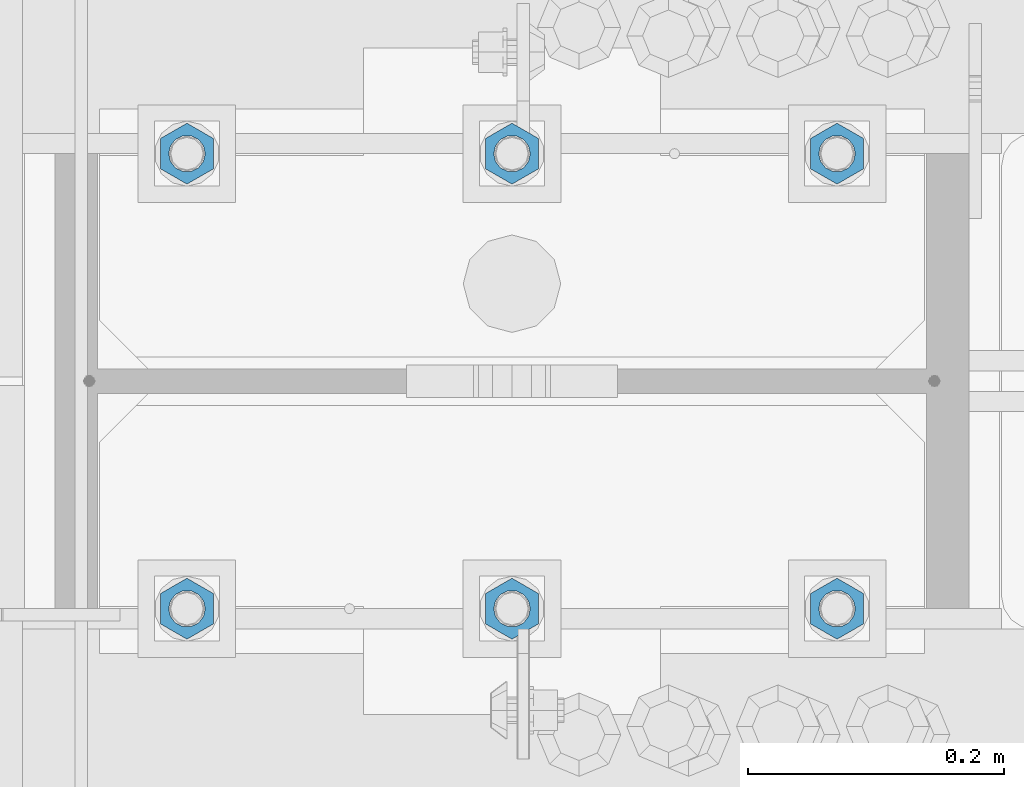
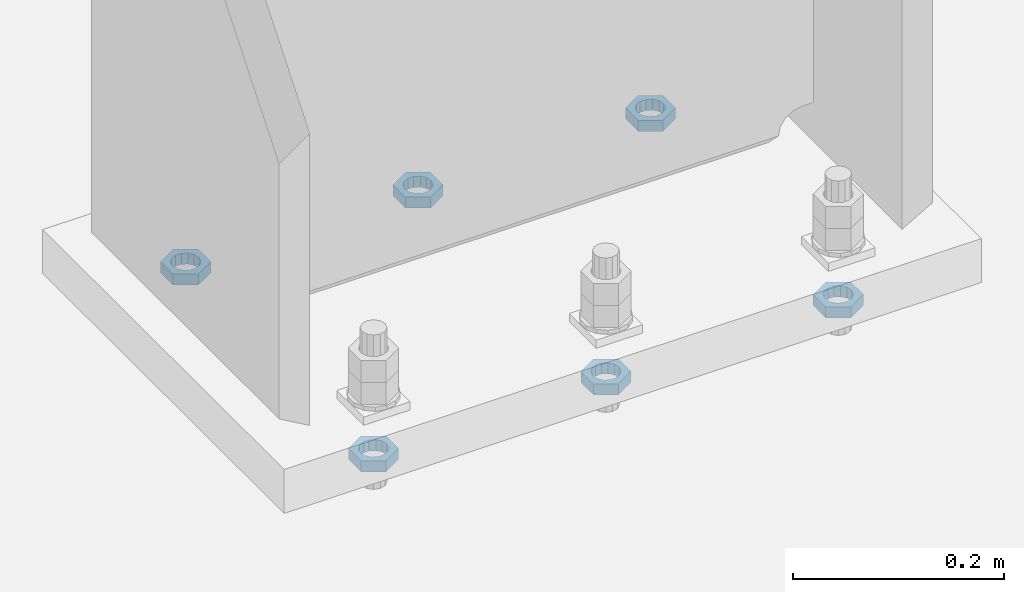
# One storey, part 1403 of 1763: 6 beams, 1 element without a shape of its own.
"""IFC2X3 building model written with IfcOpenShell, lengths in millimetres."""

from ifc_helpers import new_model, si_unit, frame, origin_with_axes, place, context, subcontext, project, spatial, faceted_brep, material, type_object, element, aggregate, save


model = new_model("IFC2X3")

# Units and contexts
model_context = context("Model", 3, precision=1e-05, world=origin_with_axes())
body_context = subcontext(model_context, "Body", "Model", "MODEL_VIEW")
ifc_project = project(units=[si_unit("LENGTHUNIT", "METRE", prefix="MILLI"), si_unit("AREAUNIT", "SQUARE_METRE"), si_unit("VOLUMEUNIT", "CUBIC_METRE"), si_unit("MASSUNIT", "GRAM", prefix="KILO"), si_unit("TIMEUNIT", "SECOND"), si_unit("PLANEANGLEUNIT", "RADIAN"), si_unit("SOLIDANGLEUNIT", "STERADIAN"), si_unit("THERMODYNAMICTEMPERATUREUNIT", "DEGREE_CELSIUS"), si_unit("LUMINOUSINTENSITYUNIT", "LUMEN")], contexts=[model_context])

# Site, building, storey
site_placement = place(None, origin_with_axes())
site = spatial("IfcSite", under=ifc_project, at=site_placement, CompositionType="ELEMENT")
building_placement = place(site_placement, origin_with_axes())
building = spatial("IfcBuilding", under=site, at=building_placement, Name="Undefined", CompositionType="ELEMENT")
storey_placement = place(building_placement, origin_with_axes())
storey = spatial("IfcBuildingStorey", under=building, at=storey_placement, Name="Undefined", CompositionType="ELEMENT", Elevation=0.0)

# Assembly, beams
assembly_placement = place(storey_placement, origin_with_axes())
assembly = element("IfcElementAssembly", 1, at=assembly_placement, inside=storey, Name="TEMPLATE", AssemblyPlace="NOTDEFINED", PredefinedType="RIGID_FRAME")
ifc_material = material(Name="STEEL/A563")
beam_type = type_object("IfcBeamType", Name="1_DIA. HALF_NUT", PredefinedType="NOTDEFINED")
beam_1_placement = place(assembly_placement, frame((-87121.4372736983, 52298.6, -266.700000000016), z_axis=(-1.0, 0.0, 0.0), x_axis=(0.0, 0.0, -1.0)))
beam_1 = element("IfcBeam", 2, at=beam_1_placement, type_object=beam_type, material=ifc_material, Name="NUT", ObjectType="1_DIA. HALF_NUT", context=body_context, shape_type="Brep", body=[
    faceted_brep([(0.0, -23.8099994659424, 0.0), (0.0, -11.9099998474121, -20.6200008392334), (12.7000000000001, -11.9099998474121, -20.6200008392334), (12.7000000000001, -23.8099994659424, 0.0), (0.0, 11.9099998474121, -20.6200008392334), (12.7000000000001, 11.9099998474121, -20.6200008392334), (0.0, 23.8099994659424, 0.0), (12.7000000000001, 23.8099994659424, 0.0), (0.0, 11.9099998474121, 20.6200008392334), (12.7000000000001, 11.9099998474121, 20.6200008392334), (0.0, -11.9099998474121, 20.6200008392334), (12.7000000000001, -11.9099998474121, 20.6200008392334), (0.0, 0.0, 14.289999961853), (0.0, 6.20019861543551, 12.8748450879575), (12.7000000000001, 6.20019861543551, 12.8748450879575), (12.7000000000001, 0.0, 14.289999961853), (0.0, 11.1723718546418, 8.90966924477834), (12.7000000000001, 11.1723718546418, 8.90966924477834), (0.0, 13.9317198278877, 3.17982413774735), (12.7000000000001, 13.9317198278877, 3.17982413774735), (0.0, 13.9317198278877, -3.17982413774735), (12.7000000000001, 13.9317198278877, -3.17982413774735), (0.0, 11.1723718546418, -8.90966924477834), (12.7000000000001, 11.1723718546418, -8.90966924477834), (0.0, 6.20019861543551, -12.8748450879575), (12.7000000000001, 6.20019861543551, -12.8748450879575), (0.0, 0.0, -14.289999961853), (12.7000000000001, 0.0, -14.289999961853), (0.0, -6.20019861543551, -12.8748450879575), (12.7000000000001, -6.20019861543551, -12.8748450879575), (0.0, -11.1723718546418, -8.90966924477834), (12.7000000000001, -11.1723718546418, -8.90966924477834), (0.0, -13.9317198278877, -3.17982413774735), (12.7000000000001, -13.9317198278877, -3.17982413774735), (0.0, -13.9317198278877, 3.17982413774735), (12.7000000000001, -13.9317198278877, 3.17982413774735), (0.0, -11.1723718546418, 8.90966924477834), (12.7000000000001, -11.1723718546418, 8.90966924477834), (0.0, -6.20019861543551, 12.8748450879575), (12.7000000000001, -6.20019861543551, 12.8748450879575)], [[[0, 1, 2, 3]], [[1, 4, 5, 2]], [[4, 6, 7, 5]], [[6, 8, 9, 7]], [[8, 10, 11, 9]], [[10, 0, 3, 11]], [[12, 13, 14, 15]], [[13, 16, 17, 14]], [[16, 18, 19, 17]], [[18, 20, 21, 19]], [[20, 22, 23, 21]], [[22, 24, 25, 23]], [[24, 26, 27, 25]], [[26, 28, 29, 27]], [[28, 30, 31, 29]], [[30, 32, 33, 31]], [[32, 34, 35, 33]], [[34, 36, 37, 35]], [[36, 38, 39, 37]], [[38, 12, 15, 39]], [[5, 7, 9, 11, 3, 2], [17, 19, 21, 23, 25, 27, 29, 31, 33, 35, 37, 39, 15, 14]], [[10, 8, 6, 4, 1, 0], [38, 36, 34, 32, 30, 28, 26, 24, 22, 20, 18, 16, 13, 12]]]),
])
beam_2_placement = place(assembly_placement, frame((-87375.4372736983, 52298.6, -266.700000000016), z_axis=(-1.0, 0.0, 0.0), x_axis=(0.0, 0.0, -1.0)))
beam_2 = element("IfcBeam", 3, at=beam_2_placement, type_object=beam_type, material=ifc_material, Name="NUT", ObjectType="1_DIA. HALF_NUT", context=body_context, shape_type="Brep", body=[
    faceted_brep([(0.0, -23.8099994659424, 0.0), (0.0, -11.9099998474121, -20.6200008392334), (12.7000000000001, -11.9099998474121, -20.6200008392334), (12.7000000000001, -23.8099994659424, 0.0), (0.0, 11.9099998474121, -20.6200008392334), (12.7000000000001, 11.9099998474121, -20.6200008392334), (0.0, 23.8099994659424, 0.0), (12.7000000000001, 23.8099994659424, 0.0), (0.0, 11.9099998474121, 20.6200008392334), (12.7000000000001, 11.9099998474121, 20.6200008392334), (0.0, -11.9099998474121, 20.6200008392334), (12.7000000000001, -11.9099998474121, 20.6200008392334), (0.0, 0.0, 14.289999961853), (0.0, 6.20019861543551, 12.8748450879575), (12.7000000000001, 6.20019861543551, 12.8748450879575), (12.7000000000001, 0.0, 14.289999961853), (0.0, 11.1723718546418, 8.90966924477834), (12.7000000000001, 11.1723718546418, 8.90966924477834), (0.0, 13.9317198278877, 3.17982413774735), (12.7000000000001, 13.9317198278877, 3.17982413774735), (0.0, 13.9317198278877, -3.17982413774735), (12.7000000000001, 13.9317198278877, -3.17982413774735), (0.0, 11.1723718546418, -8.90966924477834), (12.7000000000001, 11.1723718546418, -8.90966924477834), (0.0, 6.20019861543551, -12.8748450879575), (12.7000000000001, 6.20019861543551, -12.8748450879575), (0.0, 0.0, -14.289999961853), (12.7000000000001, 0.0, -14.289999961853), (0.0, -6.20019861543551, -12.8748450879575), (12.7000000000001, -6.20019861543551, -12.8748450879575), (0.0, -11.1723718546418, -8.90966924477834), (12.7000000000001, -11.1723718546418, -8.90966924477834), (0.0, -13.9317198278877, -3.17982413774735), (12.7000000000001, -13.9317198278877, -3.17982413774735), (0.0, -13.9317198278877, 3.17982413774735), (12.7000000000001, -13.9317198278877, 3.17982413774735), (0.0, -11.1723718546418, 8.90966924477834), (12.7000000000001, -11.1723718546418, 8.90966924477834), (0.0, -6.20019861543551, 12.8748450879575), (12.7000000000001, -6.20019861543551, 12.8748450879575)], [[[0, 1, 2, 3]], [[1, 4, 5, 2]], [[4, 6, 7, 5]], [[6, 8, 9, 7]], [[8, 10, 11, 9]], [[10, 0, 3, 11]], [[12, 13, 14, 15]], [[13, 16, 17, 14]], [[16, 18, 19, 17]], [[18, 20, 21, 19]], [[20, 22, 23, 21]], [[22, 24, 25, 23]], [[24, 26, 27, 25]], [[26, 28, 29, 27]], [[28, 30, 31, 29]], [[30, 32, 33, 31]], [[32, 34, 35, 33]], [[34, 36, 37, 35]], [[36, 38, 39, 37]], [[38, 12, 15, 39]], [[5, 7, 9, 11, 3, 2], [17, 19, 21, 23, 25, 27, 29, 31, 33, 35, 37, 39, 15, 14]], [[10, 8, 6, 4, 1, 0], [38, 36, 34, 32, 30, 28, 26, 24, 22, 20, 18, 16, 13, 12]]]),
])
beam_3_placement = place(assembly_placement, frame((-87629.4372736983, 52298.6, -266.700000000016), z_axis=(-1.0, 0.0, 0.0), x_axis=(0.0, 0.0, -1.0)))
beam_3 = element("IfcBeam", 4, at=beam_3_placement, type_object=beam_type, material=ifc_material, Name="NUT", ObjectType="1_DIA. HALF_NUT", context=body_context, shape_type="Brep", body=[
    faceted_brep([(0.0, -23.8099994659424, 0.0), (0.0, -11.9099998474121, -20.6200008392334), (12.7000000000001, -11.9099998474121, -20.6200008392334), (12.7000000000001, -23.8099994659424, 0.0), (0.0, 11.9099998474121, -20.6200008392334), (12.7000000000001, 11.9099998474121, -20.6200008392334), (0.0, 23.8099994659424, 0.0), (12.7000000000001, 23.8099994659424, 0.0), (0.0, 11.9099998474121, 20.6200008392334), (12.7000000000001, 11.9099998474121, 20.6200008392334), (0.0, -11.9099998474121, 20.6200008392334), (12.7000000000001, -11.9099998474121, 20.6200008392334), (0.0, 0.0, 14.289999961853), (0.0, 6.20019861543551, 12.8748450879575), (12.7000000000001, 6.20019861543551, 12.8748450879575), (12.7000000000001, 0.0, 14.289999961853), (0.0, 11.1723718546418, 8.90966924477834), (12.7000000000001, 11.1723718546418, 8.90966924477834), (0.0, 13.9317198278877, 3.17982413774735), (12.7000000000001, 13.9317198278877, 3.17982413774735), (0.0, 13.9317198278877, -3.17982413774735), (12.7000000000001, 13.9317198278877, -3.17982413774735), (0.0, 11.1723718546418, -8.90966924477834), (12.7000000000001, 11.1723718546418, -8.90966924477834), (0.0, 6.20019861543551, -12.8748450879575), (12.7000000000001, 6.20019861543551, -12.8748450879575), (0.0, 0.0, -14.289999961853), (12.7000000000001, 0.0, -14.289999961853), (0.0, -6.20019861543551, -12.8748450879575), (12.7000000000001, -6.20019861543551, -12.8748450879575), (0.0, -11.1723718546418, -8.90966924477834), (12.7000000000001, -11.1723718546418, -8.90966924477834), (0.0, -13.9317198278877, -3.17982413774735), (12.7000000000001, -13.9317198278877, -3.17982413774735), (0.0, -13.9317198278877, 3.17982413774735), (12.7000000000001, -13.9317198278877, 3.17982413774735), (0.0, -11.1723718546418, 8.90966924477834), (12.7000000000001, -11.1723718546418, 8.90966924477834), (0.0, -6.20019861543551, 12.8748450879575), (12.7000000000001, -6.20019861543551, 12.8748450879575)], [[[0, 1, 2, 3]], [[1, 4, 5, 2]], [[4, 6, 7, 5]], [[6, 8, 9, 7]], [[8, 10, 11, 9]], [[10, 0, 3, 11]], [[12, 13, 14, 15]], [[13, 16, 17, 14]], [[16, 18, 19, 17]], [[18, 20, 21, 19]], [[20, 22, 23, 21]], [[22, 24, 25, 23]], [[24, 26, 27, 25]], [[26, 28, 29, 27]], [[28, 30, 31, 29]], [[30, 32, 33, 31]], [[32, 34, 35, 33]], [[34, 36, 37, 35]], [[36, 38, 39, 37]], [[38, 12, 15, 39]], [[5, 7, 9, 11, 3, 2], [17, 19, 21, 23, 25, 27, 29, 31, 33, 35, 37, 39, 15, 14]], [[10, 8, 6, 4, 1, 0], [38, 36, 34, 32, 30, 28, 26, 24, 22, 20, 18, 16, 13, 12]]]),
])
beam_4_placement = place(assembly_placement, frame((-87629.4372736983, 51943.0, -266.700000000016), z_axis=(1.0, 0.0, 0.0), x_axis=(0.0, 0.0, -1.0)))
beam_4 = element("IfcBeam", 5, at=beam_4_placement, type_object=beam_type, material=ifc_material, Name="NUT", ObjectType="1_DIA. HALF_NUT", context=body_context, shape_type="Brep", body=[
    faceted_brep([(0.0, -23.8099994659424, 0.0), (0.0, -11.9099998474121, -20.6200008392334), (12.7000000000001, -11.9099998474121, -20.6200008392334), (12.7000000000001, -23.8099994659424, 0.0), (0.0, 11.9099998474121, -20.6200008392334), (12.7000000000001, 11.9099998474121, -20.6200008392334), (0.0, 23.8099994659424, 0.0), (12.7000000000001, 23.8099994659424, 0.0), (0.0, 11.9099998474121, 20.6200008392334), (12.7000000000001, 11.9099998474121, 20.6200008392334), (0.0, -11.9099998474121, 20.6200008392334), (12.7000000000001, -11.9099998474121, 20.6200008392334), (0.0, 0.0, 14.289999961853), (0.0, 6.20019861543551, 12.8748450879575), (12.7000000000001, 6.20019861543551, 12.8748450879575), (12.7000000000001, 0.0, 14.289999961853), (0.0, 11.1723718546418, 8.90966924477834), (12.7000000000001, 11.1723718546418, 8.90966924477834), (0.0, 13.9317198278877, 3.17982413774735), (12.7000000000001, 13.9317198278877, 3.17982413774735), (0.0, 13.9317198278877, -3.17982413774735), (12.7000000000001, 13.9317198278877, -3.17982413774735), (0.0, 11.1723718546418, -8.90966924477834), (12.7000000000001, 11.1723718546418, -8.90966924477834), (0.0, 6.20019861543551, -12.8748450879575), (12.7000000000001, 6.20019861543551, -12.8748450879575), (0.0, 0.0, -14.289999961853), (12.7000000000001, 0.0, -14.289999961853), (0.0, -6.20019861543551, -12.8748450879575), (12.7000000000001, -6.20019861543551, -12.8748450879575), (0.0, -11.1723718546418, -8.90966924477834), (12.7000000000001, -11.1723718546418, -8.90966924477834), (0.0, -13.9317198278877, -3.17982413774735), (12.7000000000001, -13.9317198278877, -3.17982413774735), (0.0, -13.9317198278877, 3.17982413774735), (12.7000000000001, -13.9317198278877, 3.17982413774735), (0.0, -11.1723718546418, 8.90966924477834), (12.7000000000001, -11.1723718546418, 8.90966924477834), (0.0, -6.20019861543551, 12.8748450879575), (12.7000000000001, -6.20019861543551, 12.8748450879575)], [[[0, 1, 2, 3]], [[1, 4, 5, 2]], [[4, 6, 7, 5]], [[6, 8, 9, 7]], [[8, 10, 11, 9]], [[10, 0, 3, 11]], [[12, 13, 14, 15]], [[13, 16, 17, 14]], [[16, 18, 19, 17]], [[18, 20, 21, 19]], [[20, 22, 23, 21]], [[22, 24, 25, 23]], [[24, 26, 27, 25]], [[26, 28, 29, 27]], [[28, 30, 31, 29]], [[30, 32, 33, 31]], [[32, 34, 35, 33]], [[34, 36, 37, 35]], [[36, 38, 39, 37]], [[38, 12, 15, 39]], [[5, 7, 9, 11, 3, 2], [17, 19, 21, 23, 25, 27, 29, 31, 33, 35, 37, 39, 15, 14]], [[10, 8, 6, 4, 1, 0], [38, 36, 34, 32, 30, 28, 26, 24, 22, 20, 18, 16, 13, 12]]]),
])
beam_5_placement = place(assembly_placement, frame((-87375.4372736983, 51943.0, -266.700000000016), z_axis=(1.0, 0.0, 0.0), x_axis=(0.0, 0.0, -1.0)))
beam_5 = element("IfcBeam", 6, at=beam_5_placement, type_object=beam_type, material=ifc_material, Name="NUT", ObjectType="1_DIA. HALF_NUT", context=body_context, shape_type="Brep", body=[
    faceted_brep([(0.0, -23.8099994659424, 0.0), (0.0, -11.9099998474121, -20.6200008392334), (12.7000000000001, -11.9099998474121, -20.6200008392334), (12.7000000000001, -23.8099994659424, 0.0), (0.0, 11.9099998474121, -20.6200008392334), (12.7000000000001, 11.9099998474121, -20.6200008392334), (0.0, 23.8099994659424, 0.0), (12.7000000000001, 23.8099994659424, 0.0), (0.0, 11.9099998474121, 20.6200008392334), (12.7000000000001, 11.9099998474121, 20.6200008392334), (0.0, -11.9099998474121, 20.6200008392334), (12.7000000000001, -11.9099998474121, 20.6200008392334), (0.0, 0.0, 14.289999961853), (0.0, 6.20019861543551, 12.8748450879575), (12.7000000000001, 6.20019861543551, 12.8748450879575), (12.7000000000001, 0.0, 14.289999961853), (0.0, 11.1723718546418, 8.90966924477834), (12.7000000000001, 11.1723718546418, 8.90966924477834), (0.0, 13.9317198278877, 3.17982413774735), (12.7000000000001, 13.9317198278877, 3.17982413774735), (0.0, 13.9317198278877, -3.17982413774735), (12.7000000000001, 13.9317198278877, -3.17982413774735), (0.0, 11.1723718546418, -8.90966924477834), (12.7000000000001, 11.1723718546418, -8.90966924477834), (0.0, 6.20019861543551, -12.8748450879575), (12.7000000000001, 6.20019861543551, -12.8748450879575), (0.0, 0.0, -14.289999961853), (12.7000000000001, 0.0, -14.289999961853), (0.0, -6.20019861543551, -12.8748450879575), (12.7000000000001, -6.20019861543551, -12.8748450879575), (0.0, -11.1723718546418, -8.90966924477834), (12.7000000000001, -11.1723718546418, -8.90966924477834), (0.0, -13.9317198278877, -3.17982413774735), (12.7000000000001, -13.9317198278877, -3.17982413774735), (0.0, -13.9317198278877, 3.17982413774735), (12.7000000000001, -13.9317198278877, 3.17982413774735), (0.0, -11.1723718546418, 8.90966924477834), (12.7000000000001, -11.1723718546418, 8.90966924477834), (0.0, -6.20019861543551, 12.8748450879575), (12.7000000000001, -6.20019861543551, 12.8748450879575)], [[[0, 1, 2, 3]], [[1, 4, 5, 2]], [[4, 6, 7, 5]], [[6, 8, 9, 7]], [[8, 10, 11, 9]], [[10, 0, 3, 11]], [[12, 13, 14, 15]], [[13, 16, 17, 14]], [[16, 18, 19, 17]], [[18, 20, 21, 19]], [[20, 22, 23, 21]], [[22, 24, 25, 23]], [[24, 26, 27, 25]], [[26, 28, 29, 27]], [[28, 30, 31, 29]], [[30, 32, 33, 31]], [[32, 34, 35, 33]], [[34, 36, 37, 35]], [[36, 38, 39, 37]], [[38, 12, 15, 39]], [[5, 7, 9, 11, 3, 2], [17, 19, 21, 23, 25, 27, 29, 31, 33, 35, 37, 39, 15, 14]], [[10, 8, 6, 4, 1, 0], [38, 36, 34, 32, 30, 28, 26, 24, 22, 20, 18, 16, 13, 12]]]),
])
beam_6_placement = place(assembly_placement, frame((-87121.4372736983, 51943.0, -266.700000000016), z_axis=(1.0, 0.0, 0.0), x_axis=(0.0, 0.0, -1.0)))
beam_6 = element("IfcBeam", 7, at=beam_6_placement, type_object=beam_type, material=ifc_material, Name="NUT", ObjectType="1_DIA. HALF_NUT", context=body_context, shape_type="Brep", body=[
    faceted_brep([(0.0, -23.8099994659424, 0.0), (0.0, -11.9099998474121, -20.6200008392334), (12.7000000000001, -11.9099998474121, -20.6200008392334), (12.7000000000001, -23.8099994659424, 0.0), (0.0, 11.9099998474121, -20.6200008392334), (12.7000000000001, 11.9099998474121, -20.6200008392334), (0.0, 23.8099994659424, 0.0), (12.7000000000001, 23.8099994659424, 0.0), (0.0, 11.9099998474121, 20.6200008392334), (12.7000000000001, 11.9099998474121, 20.6200008392334), (0.0, -11.9099998474121, 20.6200008392334), (12.7000000000001, -11.9099998474121, 20.6200008392334), (0.0, 0.0, 14.289999961853), (0.0, 6.20019861543551, 12.8748450879575), (12.7000000000001, 6.20019861543551, 12.8748450879575), (12.7000000000001, 0.0, 14.289999961853), (0.0, 11.1723718546418, 8.90966924477834), (12.7000000000001, 11.1723718546418, 8.90966924477834), (0.0, 13.9317198278877, 3.17982413774735), (12.7000000000001, 13.9317198278877, 3.17982413774735), (0.0, 13.9317198278877, -3.17982413774735), (12.7000000000001, 13.9317198278877, -3.17982413774735), (0.0, 11.1723718546418, -8.90966924477834), (12.7000000000001, 11.1723718546418, -8.90966924477834), (0.0, 6.20019861543551, -12.8748450879575), (12.7000000000001, 6.20019861543551, -12.8748450879575), (0.0, 0.0, -14.289999961853), (12.7000000000001, 0.0, -14.289999961853), (0.0, -6.20019861543551, -12.8748450879575), (12.7000000000001, -6.20019861543551, -12.8748450879575), (0.0, -11.1723718546418, -8.90966924477834), (12.7000000000001, -11.1723718546418, -8.90966924477834), (0.0, -13.9317198278877, -3.17982413774735), (12.7000000000001, -13.9317198278877, -3.17982413774735), (0.0, -13.9317198278877, 3.17982413774735), (12.7000000000001, -13.9317198278877, 3.17982413774735), (0.0, -11.1723718546418, 8.90966924477834), (12.7000000000001, -11.1723718546418, 8.90966924477834), (0.0, -6.20019861543551, 12.8748450879575), (12.7000000000001, -6.20019861543551, 12.8748450879575)], [[[0, 1, 2, 3]], [[1, 4, 5, 2]], [[4, 6, 7, 5]], [[6, 8, 9, 7]], [[8, 10, 11, 9]], [[10, 0, 3, 11]], [[12, 13, 14, 15]], [[13, 16, 17, 14]], [[16, 18, 19, 17]], [[18, 20, 21, 19]], [[20, 22, 23, 21]], [[22, 24, 25, 23]], [[24, 26, 27, 25]], [[26, 28, 29, 27]], [[28, 30, 31, 29]], [[30, 32, 33, 31]], [[32, 34, 35, 33]], [[34, 36, 37, 35]], [[36, 38, 39, 37]], [[38, 12, 15, 39]], [[5, 7, 9, 11, 3, 2], [17, 19, 21, 23, 25, 27, 29, 31, 33, 35, 37, 39, 15, 14]], [[10, 8, 6, 4, 1, 0], [38, 36, 34, 32, 30, 28, 26, 24, 22, 20, 18, 16, 13, 12]]]),
])
aggregate(assembly, [beam_1, beam_2, beam_3, beam_4, beam_5, beam_6])

save(model, "model.ifc")
